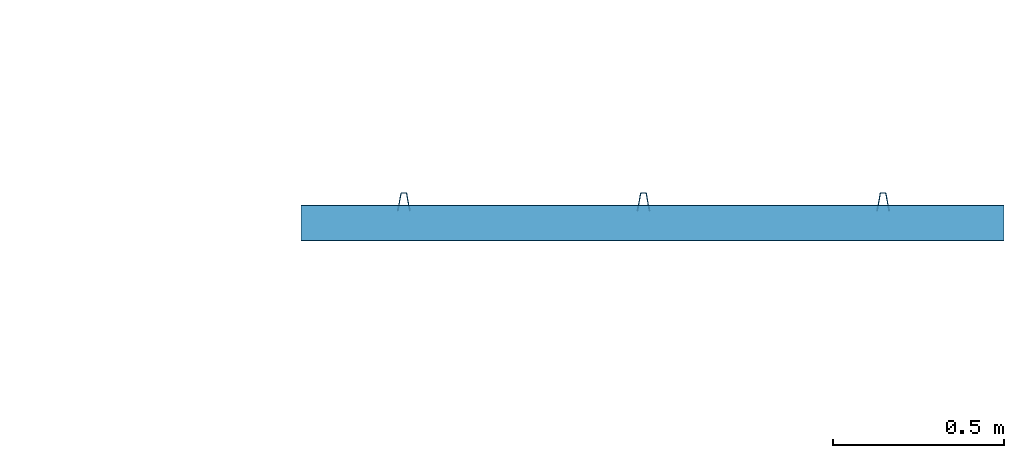
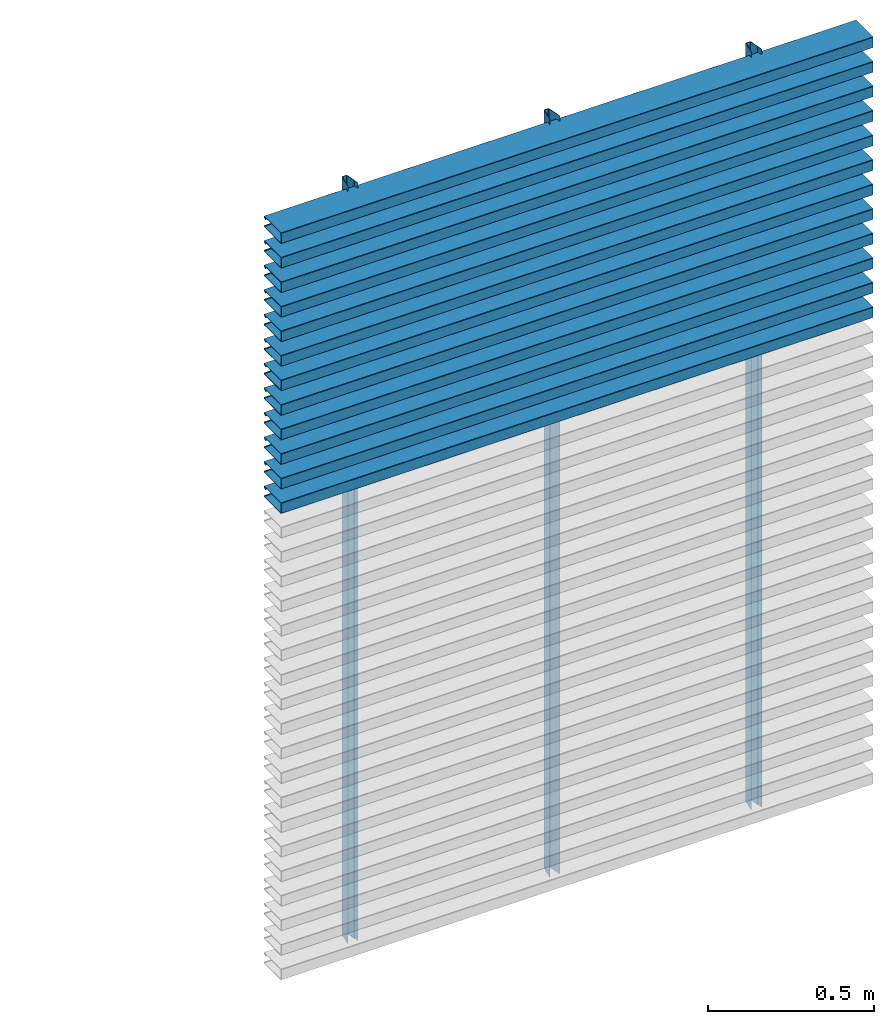
# One storey, part 2 of 3: 15 members, 2 elements without a shape of their own.
"""IFC2X3 building model written with IfcOpenShell, lengths in millimetres."""

from ifc_helpers import new_model, entity, si_unit, converted_unit, derived_unit, direction, frame, frame_2d, origin, place, context, subcontext, project, spatial, polyline, circle_curve, parameter, trimmed, segment, composite_curve, outline, extrude, source, transform, mapped, material, type_object, type_shapes, element, aggregate, save


model = new_model("IFC2X3")

# Units and contexts
model_context = context("Model", 3, precision=0.01, world=origin(), true_north=direction((6.12303176911189e-17, 1.0)))
body_context = subcontext(model_context, "Body", "Model", "MODEL_VIEW")
ifc_project = project(units=[si_unit("LENGTHUNIT", "METRE", prefix="MILLI"), si_unit("AREAUNIT", "SQUARE_METRE"), si_unit("VOLUMEUNIT", "CUBIC_METRE"), converted_unit("PLANEANGLEUNIT", "DEGREE", entity("IfcRatioMeasure", 0.0174532925199433), si_unit("PLANEANGLEUNIT", "RADIAN"), dimensions=[0, 0, 0, 0, 0, 0, 0]), si_unit("MASSUNIT", "GRAM", prefix="KILO"), derived_unit("MASSDENSITYUNIT", [(si_unit("MASSUNIT", "GRAM", prefix="KILO"), 1), (si_unit("LENGTHUNIT", "METRE"), -3)]), derived_unit("MOMENTOFINERTIAUNIT", [(si_unit("LENGTHUNIT", "METRE"), 4)]), si_unit("TIMEUNIT", "SECOND"), si_unit("FREQUENCYUNIT", "HERTZ"), si_unit("THERMODYNAMICTEMPERATUREUNIT", "DEGREE_CELSIUS"), derived_unit("THERMALTRANSMITTANCEUNIT", [(si_unit("MASSUNIT", "GRAM", prefix="KILO"), 1), (si_unit("THERMODYNAMICTEMPERATUREUNIT", "KELVIN"), -1), (si_unit("TIMEUNIT", "SECOND"), -3)]), derived_unit("VOLUMETRICFLOWRATEUNIT", [(si_unit("LENGTHUNIT", "METRE"), 3), (si_unit("TIMEUNIT", "SECOND"), -1)]), si_unit("ELECTRICCURRENTUNIT", "AMPERE"), si_unit("ELECTRICVOLTAGEUNIT", "VOLT"), si_unit("POWERUNIT", "WATT"), si_unit("FORCEUNIT", "NEWTON", prefix="KILO"), si_unit("ILLUMINANCEUNIT", "LUX"), si_unit("LUMINOUSFLUXUNIT", "LUMEN"), si_unit("LUMINOUSINTENSITYUNIT", "CANDELA"), derived_unit("USERDEFINED", [(si_unit("MASSUNIT", "GRAM", prefix="KILO"), -1), (si_unit("LENGTHUNIT", "METRE"), -2), (si_unit("TIMEUNIT", "SECOND"), 3), (si_unit("LUMINOUSFLUXUNIT", "LUMEN"), 1)]), derived_unit("LINEARVELOCITYUNIT", [(si_unit("LENGTHUNIT", "METRE"), 1), (si_unit("TIMEUNIT", "SECOND"), -1)]), si_unit("PRESSUREUNIT", "PASCAL"), derived_unit("USERDEFINED", [(si_unit("LENGTHUNIT", "METRE"), -2), (si_unit("MASSUNIT", "GRAM", prefix="KILO"), 1), (si_unit("TIMEUNIT", "SECOND"), -2)]), derived_unit("LINEARFORCEUNIT", [(si_unit("MASSUNIT", "GRAM", prefix="KILO"), 1), (si_unit("LENGTHUNIT", "METRE"), 1), (si_unit("TIMEUNIT", "SECOND"), -2), (si_unit("LENGTHUNIT", "METRE"), -1)]), derived_unit("PLANARFORCEUNIT", [(si_unit("MASSUNIT", "GRAM", prefix="KILO"), 1), (si_unit("LENGTHUNIT", "METRE"), 1), (si_unit("TIMEUNIT", "SECOND"), -2), (si_unit("LENGTHUNIT", "METRE"), -2)])], contexts=[model_context])

# Site, building, storey
site_placement = place(None, origin())
site = spatial("IfcSite", under=ifc_project, at=site_placement, CompositionType="ELEMENT")
building_placement = place(site_placement, origin())
building = spatial("IfcBuilding", under=site, at=building_placement, CompositionType="ELEMENT")
storey_placement = place(building_placement, origin())
storey = spatial("IfcBuildingStorey", under=building, at=storey_placement, Name="Level 1", CompositionType="ELEMENT", Elevation=0.0)

# Curtain wall, members
curtain_wall_type_1 = type_object("IfcCurtainWallType", PredefinedType="NOTDEFINED")
curtain_wall_1_placement = place(storey_placement, origin())
curtain_wall_1 = element("IfcCurtainWall", 1, at=curtain_wall_1_placement, inside=storey, type_object=curtain_wall_type_1)
ifc_material = material(Name="NBS_PolyesterFibrePET_White")
member_type_1 = type_object("IfcMemberType", PredefinedType="MULLION", material=ifc_material)
shared_shape_1 = source(origin(), body_context, "Body", "SweptSolid", [
    extrude(outline(composite_curve([segment(polyline([(-5.91172214990856, -23.0797556701551), (5.91172214990867, -23.0797556701551)]), True, "CONTINUOUS"), segment(trimmed(circle_curve(frame_2d((5.91172214990869, -19.5797556701551), x_axis=(0.0, -1.0)), 3.5), [parameter(0.0)], [parameter(79.9891974524564)], True, "PARAMETER"), True, "CONTINUOUS"), segment(polyline([(9.35843463547985, -20.1881741460481), (18.0537610900885, 29.0711620587445)]), True, "CONTINUOUS"), segment(polyline([(18.0537610900885, 29.0711620587445), (17.1182248440038, 29.236304216487)]), True, "CONTINUOUS"), segment(polyline([(17.1182248440038, 29.236304216487), (14.1859952637154, 12.6251184859606)]), True, "CONTINUOUS"), segment(polyline([(14.1859952637154, 12.6251184859606), (13.2359636633338, 12.6251184859606)]), True, "CONTINUOUS"), segment(polyline([(13.2359636633338, 12.6251184859606), (7.63365181881013, -19.1121790282936)]), True, "CONTINUOUS"), segment(trimmed(circle_curve(frame_2d((5.17171432911645, -18.6775944026558), x_axis=(0.984774995877474, -0.173833850255129)), 2.5), [parameter(280.010802547544)], [parameter(0.0)], True, "PARAMETER"), False, "CONTINUOUS"), segment(polyline([(5.17171432911645, -21.1775944026558), (-5.17171432911632, -21.1775944026558)]), True, "CONTINUOUS"), segment(trimmed(circle_curve(frame_2d((-5.17171432911631, -18.6775944026558), x_axis=(0.0, -1.0)), 2.49999999999999), [parameter(280.010802547544)], [parameter(0.0)], True, "PARAMETER"), False, "CONTINUOUS"), segment(polyline([(-7.63365181880999, -19.1121790282936), (-13.2359636633339, 12.6251184859605)]), True, "CONTINUOUS"), segment(polyline([(-13.2359636633339, 12.6251184859605), (-14.1859952637155, 12.6251184859605)]), True, "CONTINUOUS"), segment(polyline([(-14.1859952637155, 12.6251184859605), (-17.118224844004, 29.2363042164869)]), True, "CONTINUOUS"), segment(polyline([(-17.118224844004, 29.2363042164869), (-18.0537610900887, 29.0711620587444)]), True, "CONTINUOUS"), segment(polyline([(-18.0537610900887, 29.0711620587444), (-9.3584346354797, -20.1881741460481)]), True, "CONTINUOUS"), segment(trimmed(circle_curve(frame_2d((-5.91172214990854, -19.5797556701551), x_axis=(-0.984774995877476, -0.173833850255114)), 3.5), [parameter(0.0)], [parameter(79.989197452456)], True, "PARAMETER"), True, "CONTINUOUS")], self_intersect=False)), frame((0.0, -29.2427591458207, -2780.0)), (0.0, 0.0, 1.0), 2780.0),
])
type_shapes(member_type_1, [shared_shape_1])
member_1_placement = place(storey_placement, frame((3081.2980673547, 3413.37904497088, 0.0), z_axis=(0.0, 0.0, -1.0), x_axis=(1.0, 0.0, 0.0)))
member_1 = element("IfcMember", 2, at=member_1_placement, type_object=member_type_1, material=ifc_material, context=body_context, shape_type="MappedRepresentation", body=[
    mapped(shared_shape_1, transform((0.0, 0.0, 0.0), scale=1.0)),
])
member_2_placement = place(storey_placement, frame((3781.2980673547, 3413.37904497088, 0.0), z_axis=(0.0, 0.0, -1.0), x_axis=(1.0, 0.0, 0.0)))
member_2 = element("IfcMember", 3, at=member_2_placement, type_object=member_type_1, material=ifc_material, context=body_context, shape_type="MappedRepresentation", body=[
    mapped(shared_shape_1, transform((0.0, 0.0, 0.0), scale=1.0)),
])
member_3_placement = place(storey_placement, frame((4481.2980673547, 3413.37904497088, 0.0), z_axis=(0.0, 0.0, -1.0), x_axis=(1.0, 0.0, 0.0)))
member_3 = element("IfcMember", 4, at=member_3_placement, type_object=member_type_1, material=ifc_material, context=body_context, shape_type="MappedRepresentation", body=[
    mapped(shared_shape_1, transform((0.0, 0.0, 0.0), scale=1.0)),
])
aggregate(curtain_wall_1, [member_1, member_2, member_3])

curtain_wall_type_2 = type_object("IfcCurtainWallType", PredefinedType="NOTDEFINED")
curtain_wall_2_placement = place(storey_placement, origin())
curtain_wall_2 = element("IfcCurtainWall", 5, at=curtain_wall_2_placement, inside=storey, type_object=curtain_wall_type_2)
member_type_2 = type_object("IfcMemberType", PredefinedType="MULLION", material=ifc_material)
shared_shape_2 = source(origin(), body_context, "Body", "SweptSolid", [
    extrude(outline(composite_curve([segment(polyline([(-58.2172353514992, -20.0), (41.5064366235799, -20.0)]), True, "CONTINUOUS"), segment(trimmed(circle_curve(frame_2d((41.5064366235799, -17.2947666541993), x_axis=(0.0, -1.0)), 2.70523334580068), [parameter(0.0)], [parameter(144.999999521531)], True, "PARAMETER"), True, "CONTINUOUS"), segment(polyline([(43.0580947440677, -15.0787692416656), (35.4091908097754, -9.72294895264017)]), True, "CONTINUOUS"), segment(polyline([(35.4091908097754, -9.72294895264017), (34.1473226498031, -11.525083450076)]), True, "CONTINUOUS"), segment(polyline([(34.1473226498031, -11.5250834500759), (41.0304174033758, -16.3446783684007)]), True, "CONTINUOUS"), segment(trimmed(circle_curve(frame_2d((40.5715562488225, -17.0), x_axis=(0.573576443191669, 0.819152039499135)), 0.800000000000003), [parameter(215.000000478469)], [parameter(0.0)], True, "PARAMETER"), False, "CONTINUOUS"), segment(polyline([(40.5715562488225, -17.8), (-57.9019277093083, -17.7999999999998)]), True, "CONTINUOUS"), segment(trimmed(circle_curve(frame_2d((-57.9019277093082, -17.0), x_axis=(0.0, -1.0)), 0.800000000000006), [parameter(270.000000000002)], [parameter(0.0)], True, "PARAMETER"), False, "CONTINUOUS"), segment(polyline([(-58.7019277093083, -17.0), (-58.7019277093082, 17.0)]), True, "CONTINUOUS"), segment(trimmed(circle_curve(frame_2d((-57.9019277093083, 17.0), x_axis=(-1.0, 0.0)), 0.800000000000007), [parameter(270.000000000002)], [parameter(0.0)], True, "PARAMETER"), False, "CONTINUOUS"), segment(polyline([(-57.9019277093083, 17.7999999999998), (40.5715562488224, 17.8)]), True, "CONTINUOUS"), segment(trimmed(circle_curve(frame_2d((40.5715562488224, 17.0), x_axis=(0.0, 1.0)), 0.8), [parameter(215.000000478469)], [parameter(0.0)], True, "PARAMETER"), False, "CONTINUOUS"), segment(polyline([(41.0304174033758, 16.3446783684007), (34.147322649803, 11.5250834500759)]), True, "CONTINUOUS"), segment(polyline([(34.147322649803, 11.5250834500759), (35.4091908097753, 9.72294895264016)]), True, "CONTINUOUS"), segment(polyline([(35.4091908097753, 9.72294895264017), (43.0580947440676, 15.0787692416656)]), True, "CONTINUOUS"), segment(trimmed(circle_curve(frame_2d((41.5064366235798, 17.2947666541993), x_axis=(0.573576443191662, -0.819152039499143)), 2.70523334580069), [parameter(0.0)], [parameter(144.999999521532)], True, "PARAMETER"), True, "CONTINUOUS"), segment(polyline([(41.5064366235798, 20.0), (-58.2172353514993, 20.0)]), True, "CONTINUOUS"), segment(trimmed(circle_curve(frame_2d((-58.2172353514992, 17.3153076421907), x_axis=(0.0, 1.0)), 2.68469235780906), [parameter(0.0)], [parameter(89.9999999999993)], True, "PARAMETER"), True, "CONTINUOUS"), segment(polyline([(-60.9019277093082, 17.3153076421908), (-60.9019277093083, -17.3153076421908)]), True, "CONTINUOUS"), segment(trimmed(circle_curve(frame_2d((-58.2172353514992, -17.3153076421908), x_axis=(-1.0, 0.0)), 2.68469235780904), [parameter(0.0)], [parameter(90.0000000000005)], True, "PARAMETER"), True, "CONTINUOUS")], self_intersect=False)), frame((0.0, 44.2095636081343, -2053.04571376474), z_axis=(0.0, 0.0, 1.0), x_axis=(0.0, -1.0, 0.0)), (0.0, 0.0, 1.0), 2053.04571376474),
])
type_shapes(member_type_2, [shared_shape_2])
member_4_placement = place(storey_placement, frame((4834.4582193015, 3430.12593951945, 1749.98284358772), z_axis=(1.0, 0.0, 0.0), x_axis=(0.0, 0.0, 1.0)))
member_4 = element("IfcMember", 6, at=member_4_placement, type_object=member_type_2, material=ifc_material, context=body_context, shape_type="MappedRepresentation", body=[
    mapped(shared_shape_2, transform((0.0, 0.0, 0.0), scale=1.0)),
])
member_5_placement = place(storey_placement, frame((4834.4582193015, 3430.12593951945, 1839.98284358772), z_axis=(1.0, 0.0, 0.0), x_axis=(0.0, 0.0, 1.0)))
member_5 = element("IfcMember", 7, at=member_5_placement, type_object=member_type_2, material=ifc_material, context=body_context, shape_type="MappedRepresentation", body=[
    mapped(shared_shape_2, transform((0.0, 0.0, 0.0), scale=1.0)),
])
member_6_placement = place(storey_placement, frame((4834.4582193015, 3430.12593951945, 1929.98284358772), z_axis=(1.0, 0.0, 0.0), x_axis=(0.0, 0.0, 1.0)))
member_6 = element("IfcMember", 8, at=member_6_placement, type_object=member_type_2, material=ifc_material, context=body_context, shape_type="MappedRepresentation", body=[
    mapped(shared_shape_2, transform((0.0, 0.0, 0.0), scale=1.0)),
])
member_7_placement = place(storey_placement, frame((4834.4582193015, 3430.12593951945, 2019.98284358772), z_axis=(1.0, 0.0, 0.0), x_axis=(0.0, 0.0, 1.0)))
member_7 = element("IfcMember", 9, at=member_7_placement, type_object=member_type_2, material=ifc_material, context=body_context, shape_type="MappedRepresentation", body=[
    mapped(shared_shape_2, transform((0.0, 0.0, 0.0), scale=1.0)),
])
member_8_placement = place(storey_placement, frame((4834.4582193015, 3430.12593951945, 2109.98284358772), z_axis=(1.0, 0.0, 0.0), x_axis=(0.0, 0.0, 1.0)))
member_8 = element("IfcMember", 10, at=member_8_placement, type_object=member_type_2, material=ifc_material, context=body_context, shape_type="MappedRepresentation", body=[
    mapped(shared_shape_2, transform((0.0, 0.0, 0.0), scale=1.0)),
])
member_9_placement = place(storey_placement, frame((4834.4582193015, 3430.12593951945, 2199.98284358772), z_axis=(1.0, 0.0, 0.0), x_axis=(0.0, 0.0, 1.0)))
member_9 = element("IfcMember", 11, at=member_9_placement, type_object=member_type_2, material=ifc_material, context=body_context, shape_type="MappedRepresentation", body=[
    mapped(shared_shape_2, transform((0.0, 0.0, 0.0), scale=1.0)),
])
member_10_placement = place(storey_placement, frame((4834.4582193015, 3430.12593951945, 2289.98284358772), z_axis=(1.0, 0.0, 0.0), x_axis=(0.0, 0.0, 1.0)))
member_10 = element("IfcMember", 12, at=member_10_placement, type_object=member_type_2, material=ifc_material, context=body_context, shape_type="MappedRepresentation", body=[
    mapped(shared_shape_2, transform((0.0, 0.0, 0.0), scale=1.0)),
])
member_11_placement = place(storey_placement, frame((4834.4582193015, 3430.12593951945, 2379.98284358772), z_axis=(1.0, 0.0, 0.0), x_axis=(0.0, 0.0, 1.0)))
member_11 = element("IfcMember", 13, at=member_11_placement, type_object=member_type_2, material=ifc_material, context=body_context, shape_type="MappedRepresentation", body=[
    mapped(shared_shape_2, transform((0.0, 0.0, 0.0), scale=1.0)),
])
member_12_placement = place(storey_placement, frame((4834.4582193015, 3430.12593951945, 2469.98284358772), z_axis=(1.0, 0.0, 0.0), x_axis=(0.0, 0.0, 1.0)))
member_12 = element("IfcMember", 14, at=member_12_placement, type_object=member_type_2, material=ifc_material, context=body_context, shape_type="MappedRepresentation", body=[
    mapped(shared_shape_2, transform((0.0, 0.0, 0.0), scale=1.0)),
])
member_13_placement = place(storey_placement, frame((4834.4582193015, 3430.12593951945, 2559.98284358772), z_axis=(1.0, 0.0, 0.0), x_axis=(0.0, 0.0, 1.0)))
member_13 = element("IfcMember", 15, at=member_13_placement, type_object=member_type_2, material=ifc_material, context=body_context, shape_type="MappedRepresentation", body=[
    mapped(shared_shape_2, transform((0.0, 0.0, 0.0), scale=1.0)),
])
member_14_placement = place(storey_placement, frame((4834.4582193015, 3430.12593951945, 2649.98284358772), z_axis=(1.0, 0.0, 0.0), x_axis=(0.0, 0.0, 1.0)))
member_14 = element("IfcMember", 16, at=member_14_placement, type_object=member_type_2, material=ifc_material, context=body_context, shape_type="MappedRepresentation", body=[
    mapped(shared_shape_2, transform((0.0, 0.0, 0.0), scale=1.0)),
])
member_15_placement = place(storey_placement, frame((4834.4582193015, 3430.12593951945, 2739.98284358772), z_axis=(1.0, 0.0, 0.0), x_axis=(0.0, 0.0, 1.0)))
member_15 = element("IfcMember", 17, at=member_15_placement, type_object=member_type_2, material=ifc_material, context=body_context, shape_type="MappedRepresentation", body=[
    mapped(shared_shape_2, transform((0.0, 0.0, 0.0), scale=1.0)),
])
aggregate(curtain_wall_2, [member_4, member_5, member_6, member_7, member_8, member_9, member_10, member_11, member_12, member_13, member_14, member_15])

save(model, "model.ifc")
